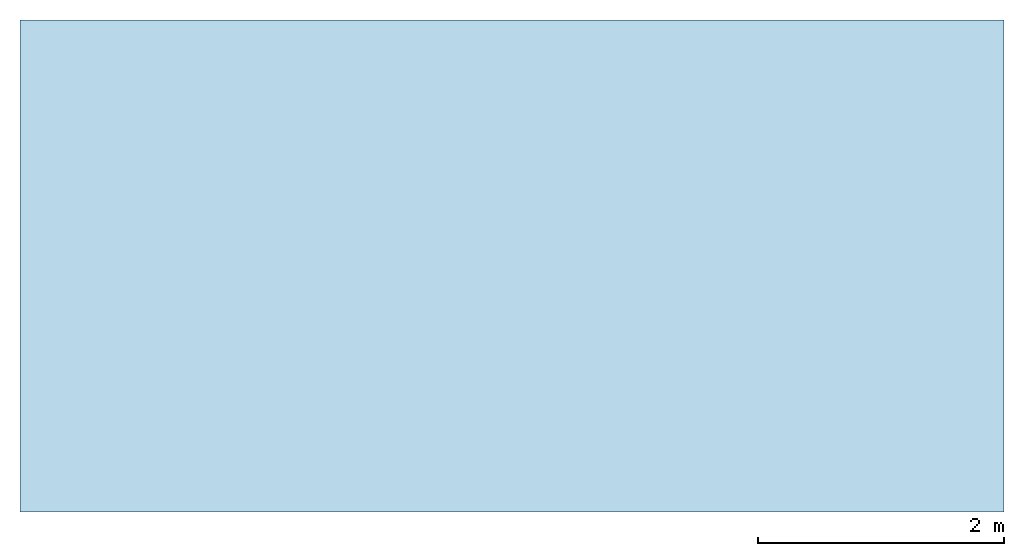
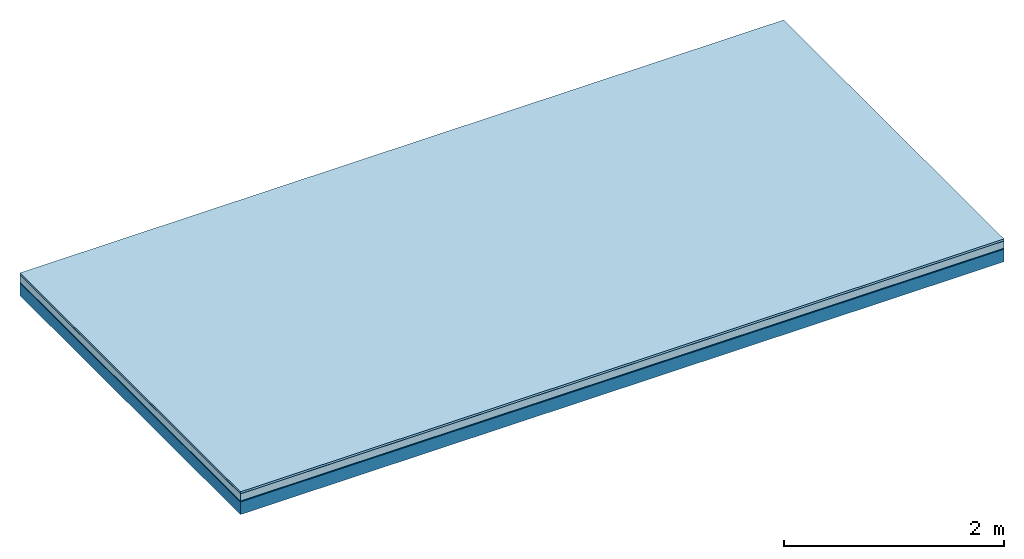
# One storey: 5 plates, 1 member, 1 element without a shape of its own.
"""IFC4 building model written with IfcOpenShell, lengths in metres."""

from ifc_helpers import new_model, si_unit, derived_unit, direction, frame, frame_2d, origin, origin_with_axes, place, context, project, spatial, rectangle, extrude, material, layer, layer_set, type_object, element, aggregate, save


model = new_model("IFC4")

# Units and contexts
plan_context = context("Plan", 3, precision=1e-05, world=origin(), true_north=direction((0.0, 1.0)))
model_context = context("Model", 3, precision=1e-05, world=origin(), true_north=direction((0.0, 1.0)))
ifc_project = project(units=[si_unit("LENGTHUNIT", "METRE"), derived_unit("SOUNDPRESSUREUNIT", [(si_unit("PRESSUREUNIT", "PASCAL", prefix="MICRO"), 0)]), si_unit("ENERGYUNIT", "JOULE", prefix="MEGA"), si_unit("MASSUNIT", "GRAM", prefix="KILO"), derived_unit("THERMALTRANSMITTANCEUNIT", [(si_unit("POWERUNIT", "WATT"), 1), (si_unit("AREAUNIT", "SQUARE_METRE"), -1), (si_unit("THERMODYNAMICTEMPERATUREUNIT", "KELVIN"), -1)]), derived_unit("AREADENSITYUNIT", [(si_unit("MASSUNIT", "GRAM", prefix="KILO"), 1), (si_unit("AREAUNIT", "SQUARE_METRE"), -1)]), derived_unit("USERDEFINED", [(si_unit("ENERGYUNIT", "JOULE", prefix="MEGA"), 1), (si_unit("AREAUNIT", "SQUARE_METRE"), -1)])], contexts=[plan_context, model_context])

# Site, building, storey
site = spatial("IfcSite", under=ifc_project)
building_placement = place(None, origin())
building = spatial("IfcBuilding", under=site, at=building_placement)
storey_placement = place(building_placement, origin())
storey = spatial("IfcBuildingStorey", under=building, at=storey_placement)

# Slab, member, plates
ifc_material_1 = material(Name="with tongue and groove", Category="07.009")
ifc_layer_1 = layer(ifc_material_1, 0.022, Name="Flooring")
ifc_material_2 = material(Category="09.006")
ifc_layer_2 = layer(ifc_material_2, 0.0005, Name="layer")
ifc_material_3 = material(Category="07.011")
ifc_layer_3 = layer(ifc_material_3, 0.08, Name="On-material")
ifc_material_4 = material(Name="Wood fiber generic product", Category="10.009")
ifc_layer_4 = layer(ifc_material_4, 0.01, Name="Impact sound insulation")
ifc_material_5 = material(Name="protection", Category="09.007")
ifc_layer_5 = layer(ifc_material_5, 0.0005, Name="Sub-floor")
ifc_material_6 = material(Name="no composite action")
ifc_layer_6 = layer(ifc_material_6, 0.0, Name="Bond")
ifc_layer_7 = layer(None, 0.14, Name="Supporting structure")
ifc_layer_set = layer_set([ifc_layer_1, ifc_layer_2, ifc_layer_3, ifc_layer_4, ifc_layer_5, ifc_layer_6, ifc_layer_7])
slab_type = type_object("IfcSlabType", Name="A2016", PredefinedType="NOTDEFINED", material=ifc_layer_set)
slab_placement = place(None, frame((0.0, 0.0, 0.0), z_axis=(0.0, 0.0, -1.0), x_axis=(1.0, 0.0, 0.0)))
slab = element("IfcSlab", 1, at=slab_placement, inside=storey, type_object=slab_type, material=ifc_layer_set, Name="Slab #1")
ifc_material_7 = material(Name="Solid timber panel")
member_placement = place(slab_placement, origin())
member = element("IfcMember", 2, at=member_placement, material=ifc_material_7, Name="Supporting structure", context=plan_context, shape_type="SweptSolid", body=[
    extrude(rectangle(XDim=1.0, YDim=0.14, at=frame_2d((0.5, 0.07), x_axis=(1.0, 0.0))), frame((0.0, 4.0, 0.113), z_axis=(0.0, -1.0, 0.0), x_axis=(1.0, 0.0, 0.0)), (0.0, 0.0, 1.0), 4.0),
    extrude(rectangle(XDim=1.0, YDim=0.14, at=frame_2d((0.5, 0.07), x_axis=(1.0, 0.0))), frame((1.0, 4.0, 0.113), z_axis=(0.0, -1.0, 0.0), x_axis=(1.0, 0.0, 0.0)), (0.0, 0.0, 1.0), 4.0),
    extrude(rectangle(XDim=1.0, YDim=0.14, at=frame_2d((0.5, 0.07), x_axis=(1.0, 0.0))), frame((2.0, 4.0, 0.113), z_axis=(0.0, -1.0, 0.0), x_axis=(1.0, 0.0, 0.0)), (0.0, 0.0, 1.0), 4.0),
    extrude(rectangle(XDim=1.0, YDim=0.14, at=frame_2d((0.5, 0.07), x_axis=(1.0, 0.0))), frame((3.0, 4.0, 0.113), z_axis=(0.0, -1.0, 0.0), x_axis=(1.0, 0.0, 0.0)), (0.0, 0.0, 1.0), 4.0),
    extrude(rectangle(XDim=1.0, YDim=0.14, at=frame_2d((0.5, 0.07), x_axis=(1.0, 0.0))), frame((4.0, 4.0, 0.113), z_axis=(0.0, -1.0, 0.0), x_axis=(1.0, 0.0, 0.0)), (0.0, 0.0, 1.0), 4.0),
    extrude(rectangle(XDim=1.0, YDim=0.14, at=frame_2d((0.5, 0.07), x_axis=(1.0, 0.0))), frame((5.0, 4.0, 0.113), z_axis=(0.0, -1.0, 0.0), x_axis=(1.0, 0.0, 0.0)), (0.0, 0.0, 1.0), 4.0),
    extrude(rectangle(XDim=1.0, YDim=0.14, at=frame_2d((0.5, 0.07), x_axis=(1.0, 0.0))), frame((6.0, 4.0, 0.113), z_axis=(0.0, -1.0, 0.0), x_axis=(1.0, 0.0, 0.0)), (0.0, 0.0, 1.0), 4.0),
    extrude(rectangle(XDim=1.0, YDim=0.14, at=frame_2d((0.5, 0.07), x_axis=(1.0, 0.0))), frame((7.0, 4.0, 0.113), z_axis=(0.0, -1.0, 0.0), x_axis=(1.0, 0.0, 0.0)), (0.0, 0.0, 1.0), 4.0),
])
plate_1_placement = place(slab_placement, origin())
plate_1 = element("IfcPlate", 3, at=plate_1_placement, material=ifc_material_1, Name="Flooring", context=plan_context, shape_type="SweptSolid", body=[
    extrude(rectangle(XDim=8.0, YDim=4.0, at=frame_2d((4.0, 2.0), x_axis=(1.0, 0.0))), origin_with_axes(), (0.0, 0.0, 1.0), 0.022),
])
plate_2_placement = place(slab_placement, origin())
plate_2 = element("IfcPlate", 4, at=plate_2_placement, material=ifc_material_2, Name="layer", context=plan_context, shape_type="SweptSolid", body=[
    extrude(rectangle(XDim=8.0, YDim=4.0, at=frame_2d((4.0, 2.0), x_axis=(1.0, 0.0))), frame((0.0, 0.0, 0.022), z_axis=(0.0, 0.0, 1.0), x_axis=(1.0, 0.0, 0.0)), (0.0, 0.0, 1.0), 0.0005),
])
plate_3_placement = place(slab_placement, origin())
plate_3 = element("IfcPlate", 5, at=plate_3_placement, material=ifc_material_3, Name="On-material", context=plan_context, shape_type="SweptSolid", body=[
    extrude(rectangle(XDim=8.0, YDim=4.0, at=frame_2d((4.0, 2.0), x_axis=(1.0, 0.0))), frame((0.0, 0.0, 0.0225), z_axis=(0.0, 0.0, 1.0), x_axis=(1.0, 0.0, 0.0)), (0.0, 0.0, 1.0), 0.08),
])
plate_4_placement = place(slab_placement, origin())
plate_4 = element("IfcPlate", 6, at=plate_4_placement, material=ifc_material_4, Name="Impact sound insulation", context=plan_context, shape_type="SweptSolid", body=[
    extrude(rectangle(XDim=8.0, YDim=4.0, at=frame_2d((4.0, 2.0), x_axis=(1.0, 0.0))), frame((0.0, 0.0, 0.1025), z_axis=(0.0, 0.0, 1.0), x_axis=(1.0, 0.0, 0.0)), (0.0, 0.0, 1.0), 0.01),
])
plate_5_placement = place(slab_placement, origin())
plate_5 = element("IfcPlate", 7, at=plate_5_placement, material=ifc_material_5, Name="Sub-floor", context=plan_context, shape_type="SweptSolid", body=[
    extrude(rectangle(XDim=8.0, YDim=4.0, at=frame_2d((4.0, 2.0), x_axis=(1.0, 0.0))), frame((0.0, 0.0, 0.1125), z_axis=(0.0, 0.0, 1.0), x_axis=(1.0, 0.0, 0.0)), (0.0, 0.0, 1.0), 0.0005),
])
aggregate(slab, [plate_1, plate_2, plate_3, plate_4, plate_5, member])

save(model, "model.ifc")
